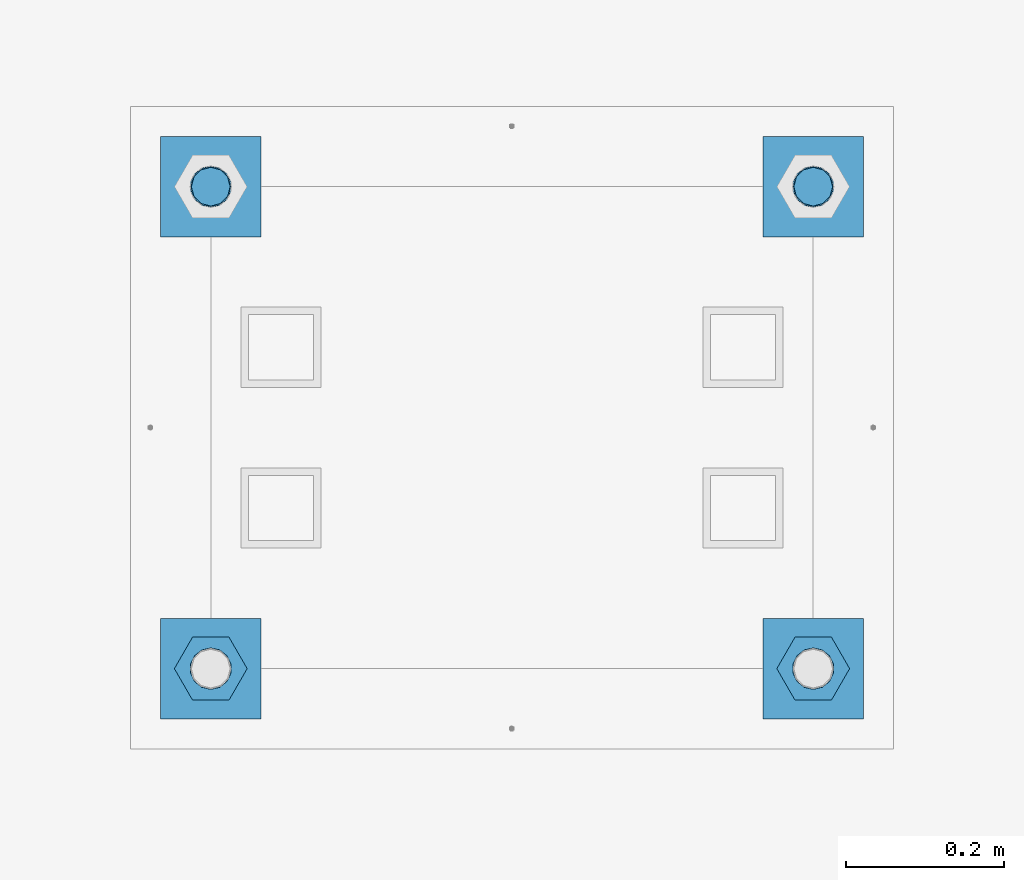
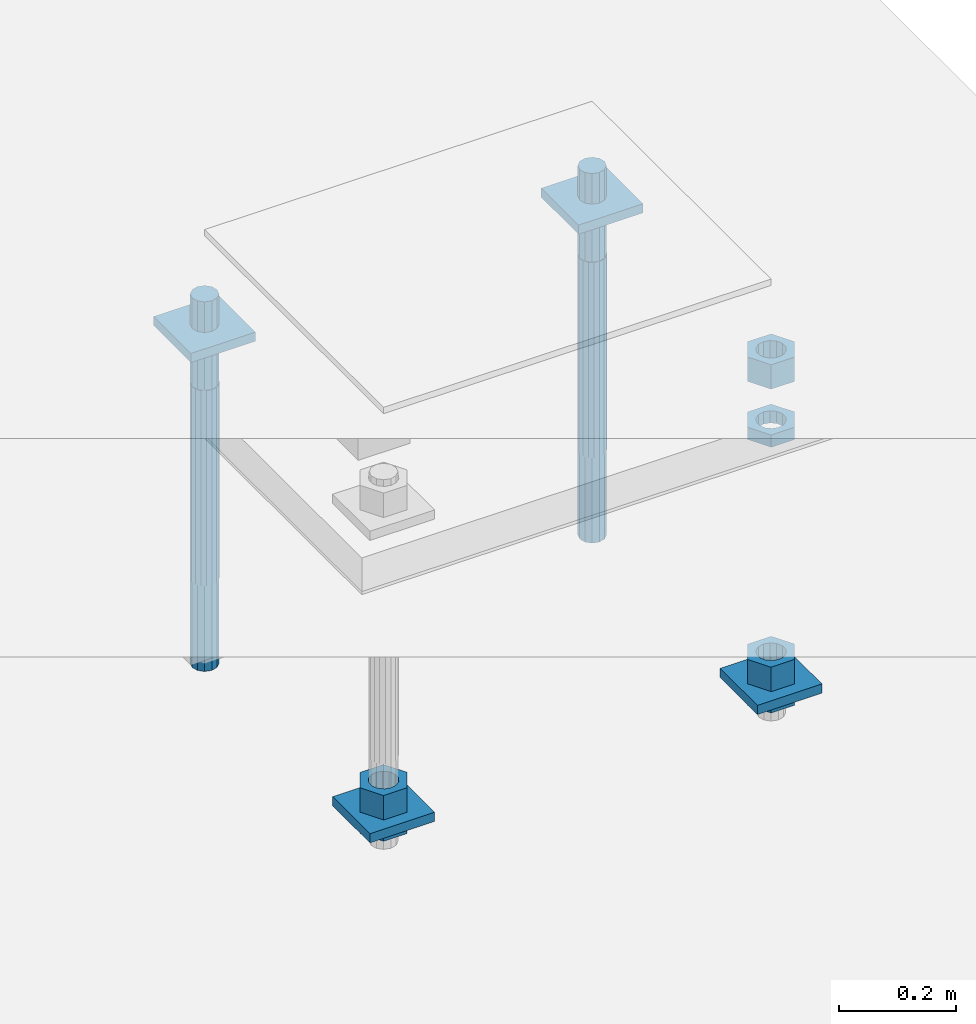
# One storey, part 2632 of 3843: 12 beams, 1 element without a shape of its own.
"""IFC2X3 building model written with IfcOpenShell, lengths in millimetres."""

import ifcopenshell
import ifcopenshell.guid

model = None  # the IFC model being written
_history = None  # IfcOwnerHistory: only IFC2X3 demands one
_inside = {}  # id of a spatial element -> (the spatial element, [elements in it])
_under = {}  # id of a project, library or spatial element -> (it, [spatial elements below it])
_declared = {}  # id of a project -> (the project, [libraries it declares])
_typed = {}  # id of a type object -> (the type object, [elements of that type])
_made_of = {}  # id of a material, layer set ... -> (it, [elements and type objects made of it])


def new_model(schema):
    """Start an empty IFC model of exactly this schema.

    Asked for "IFC4X3", IfcOpenShell would pick the latest addendum, in which some entities
    have other attributes; the version numbers below select the first issue.
    IFC2X3 requires an IfcOwnerHistory on every rooted entity: one is made here for all.
    """
    global model, _history
    if schema == "IFC4X3":
        model = ifcopenshell.file(schema_version=(4, 3, 0, 0))
    else:
        model = ifcopenshell.file(schema=schema)
    _inside.clear()
    _under.clear()
    _declared.clear()
    _typed.clear()
    _made_of.clear()
    _history = None
    if model.schema == "IFC2X3":
        org = make("IfcOrganization", Name="unknown")
        user = make(
            "IfcPersonAndOrganization",
            ThePerson=make("IfcPerson", FamilyName="unknown"),
            TheOrganization=org,
        )
        app = make(
            "IfcApplication",
            ApplicationDeveloper=org,
            Version="unknown",
            ApplicationFullName="unknown",
            ApplicationIdentifier="unknown",
        )
        _history = make(
            "IfcOwnerHistory",
            OwningUser=user,
            OwningApplication=app,
            ChangeAction="ADDED",
            CreationDate=0,
        )
    return model


def make(cls, **values):
    """One entity of the class cls with the attributes given. An attribute that is None is left unset."""
    return model.create_entity(
        cls, **{name: value for name, value in values.items() if value is not None}
    )


def rooted(cls, **values):
    """An entity with a GlobalId (a new one), such as an element, a storey or a relation."""
    return make(cls, GlobalId=ifcopenshell.guid.new(), OwnerHistory=_history, **values)


def si_unit(unit_type, name, prefix=None):
    """IfcSIUnit, for example si_unit("LENGTHUNIT", "METRE", prefix="MILLI")."""
    return make("IfcSIUnit", UnitType=unit_type, Prefix=prefix, Name=name)


def assignment(units):
    """IfcUnitAssignment: the units of a project."""
    return None if units is None else make("IfcUnitAssignment", Units=units)


def point(xyz):
    """IfcCartesianPoint."""
    return None if xyz is None else make("IfcCartesianPoint", Coordinates=xyz)


def direction(xyz):
    """IfcDirection."""
    return None if xyz is None else make("IfcDirection", DirectionRatios=xyz)


def frame(location, z_axis=None, x_axis=None):
    """IfcAxis2Placement3D, a coordinate frame: its origin and axes. An axis left out is left unset."""
    return make(
        "IfcAxis2Placement3D",
        Location=point(location),
        Axis=direction(z_axis),
        RefDirection=direction(x_axis),
    )


def origin_with_axes():
    """The frame at (0, 0, 0) with the z axis (0, 0, 1) and the x axis (1, 0, 0) written out."""
    return frame((0.0, 0.0, 0.0), z_axis=(0.0, 0.0, 1.0), x_axis=(1.0, 0.0, 0.0))


def place(relative_to, where):
    """IfcLocalPlacement: puts the frame where relative to a parent placement (None: the world)."""
    return make(
        "IfcLocalPlacement", PlacementRelTo=relative_to, RelativePlacement=where
    )


def context(
    kind, dimensions, precision=None, world=None, true_north=None, identifier=None
):
    """IfcGeometricRepresentationContext, for example the 3D "Model" context."""
    return make(
        "IfcGeometricRepresentationContext",
        ContextIdentifier=identifier,
        ContextType=kind,
        CoordinateSpaceDimension=dimensions,
        Precision=precision,
        WorldCoordinateSystem=world,
        TrueNorth=true_north,
    )


def subcontext(parent, identifier, kind, view, scale=None):
    """IfcGeometricRepresentationSubContext, for example "Body" below "Model"."""
    return make(
        "IfcGeometricRepresentationSubContext",
        ContextIdentifier=identifier,
        ContextType=kind,
        ParentContext=parent,
        TargetScale=scale,
        TargetView=view,
    )


def project(units=None, contexts=None):
    """IfcProject with its units and contexts."""
    return rooted(
        "IfcProject",
        Name="project",
        RepresentationContexts=contexts,
        UnitsInContext=assignment(units),
    )


def spatial(cls, under=None, at=None, **own):
    """A site, building, storey or space (cls), placed at a placement, below another one or the project."""
    s = rooted(cls, ObjectPlacement=at, **own)
    if under is not None:
        _under.setdefault(under.id(), (under, []))[1].append(s)
    return s


def faces_of(points, faces, orient=None, outer=None):
    """IfcFace entities. A face is a list of loops; a loop is a list of indices into points, from 0.

    orient and outer hold one flag for each loop. By default every Orientation is true, the
    first loop of a face is its IfcFaceOuterBound and the others are IfcFaceBound.
    """
    made = []
    for i, loops in enumerate(faces):
        bounds = []
        for j, loop in enumerate(loops):
            is_outer = j == 0 if outer is None else outer[i][j]
            bounds.append(
                make(
                    "IfcFaceOuterBound" if is_outer else "IfcFaceBound",
                    Bound=make("IfcPolyLoop", Polygon=[points[k] for k in loop]),
                    Orientation=True if orient is None else orient[i][j],
                )
            )
        made.append(make("IfcFace", Bounds=bounds))
    return made


def faceted_brep(points, faces, orient=None, outer=None, voids=None):
    """IfcFacetedBrep: a solid bounded by flat faces; with voids (closed shells), ...WithVoids."""
    shared = [point(p) for p in points]
    hull = make("IfcClosedShell", CfsFaces=faces_of(shared, faces, orient, outer))
    if voids is None:
        return make("IfcFacetedBrep", Outer=hull)
    return make(
        "IfcFacetedBrepWithVoids",
        Outer=hull,
        Voids=[
            make(cls, CfsFaces=faces_of(shared, fs, o, b)) for cls, fs, o, b in voids
        ],
    )


def shape(context_of_items, identifier, shape_type, items):
    """IfcShapeRepresentation: the items that make up one representation, for example the "Body"."""
    return make(
        "IfcShapeRepresentation",
        ContextOfItems=context_of_items,
        RepresentationIdentifier=identifier,
        RepresentationType=shape_type,
        Items=items,
    )


def material(Name=None, Category=None):
    """IfcMaterial."""
    return make("IfcMaterial", Name=Name, Category=Category)


def made_of(thing, what):
    """Note that an element or type object is made of a material, layer set ...; save() writes the relation."""
    if what is not None:
        _made_of.setdefault(what.id(), (what, []))[1].append(thing)
    return thing


def type_object(cls, material=None, **own):
    """A type object (cls), such as IfcWallType, which elements share."""
    return made_of(rooted(cls, **own), material)


def element(
    cls,
    number,
    at=None,
    inside=None,
    cuts=None,
    type_object=None,
    material=None,
    context=None,
    identifier="Body",
    shape_type=None,
    held_by="IfcProductDefinitionShape",
    body=None,
    shapes=None,
    **own,
):
    """One element of the class cls, such as IfcWall. Its Tag is "e" and its number.

    at: its placement. inside: the storey or other place that contains it. cuts: it is an
    opening in that element (IfcRelVoidsElement). A single representation is given by context,
    identifier, shape_type and body (its items); several are given by shapes. held_by: the class
    of the entity that holds the representations. save() writes the other relations.
    """
    e = rooted(cls, Tag="e%d" % number, ObjectPlacement=at, **own)
    if body is not None:
        shapes = [shape(context, identifier, shape_type, body)]
    if shapes is not None:
        e.Representation = make(held_by, Representations=shapes)
    if inside is not None:
        _inside.setdefault(inside.id(), (inside, []))[1].append(e)
    if cuts is not None:
        rooted(
            "IfcRelVoidsElement", RelatingBuildingElement=cuts, RelatedOpeningElement=e
        )
    if type_object is not None:
        _typed.setdefault(type_object.id(), (type_object, []))[1].append(e)
    return made_of(e, material)


def aggregate(whole, parts):
    """IfcRelAggregates: a whole, such as a stair, and the parts it consists of."""
    return rooted("IfcRelAggregates", RelatingObject=whole, RelatedObjects=parts)


def save(model, path):
    """Write the relations noted so far, then the file.

    IfcRelAggregates (storeys below a building ...), IfcRelContainedInSpatialStructure (elements
    in a storey), IfcRelDefinesByType, IfcRelAssociatesMaterial and IfcRelDeclares: one each for
    every whole, place, type object, material and project.
    """
    for whole, parts in _under.values():
        aggregate(whole, parts)
    for where, things in _inside.values():
        rooted(
            "IfcRelContainedInSpatialStructure",
            RelatedElements=things,
            RelatingStructure=where,
        )
    for kind, things in _typed.values():
        rooted("IfcRelDefinesByType", RelatedObjects=things, RelatingType=kind)
    for what, things in _made_of.values():
        rooted("IfcRelAssociatesMaterial", RelatedObjects=things, RelatingMaterial=what)
    for by, libraries in _declared.values():
        rooted("IfcRelDeclares", RelatingContext=by, RelatedDefinitions=libraries)
    model.write(path)


model = new_model("IFC2X3")

# Units and contexts
model_context = context("Model", 3, precision=1e-05, world=origin_with_axes())
body_context = subcontext(model_context, "Body", "Model", "MODEL_VIEW")
ifc_project = project(units=[si_unit("LENGTHUNIT", "METRE", prefix="MILLI"), si_unit("AREAUNIT", "SQUARE_METRE"), si_unit("VOLUMEUNIT", "CUBIC_METRE"), si_unit("MASSUNIT", "GRAM", prefix="KILO"), si_unit("TIMEUNIT", "SECOND"), si_unit("PLANEANGLEUNIT", "RADIAN"), si_unit("SOLIDANGLEUNIT", "STERADIAN"), si_unit("THERMODYNAMICTEMPERATUREUNIT", "DEGREE_CELSIUS"), si_unit("LUMINOUSINTENSITYUNIT", "LUMEN")], contexts=[model_context])

# Site, building, storey
site_placement = place(None, origin_with_axes())
site = spatial("IfcSite", under=ifc_project, at=site_placement, CompositionType="ELEMENT")
building_placement = place(site_placement, origin_with_axes())
building = spatial("IfcBuilding", under=site, at=building_placement, Name="Undefined", CompositionType="ELEMENT")
storey_placement = place(building_placement, origin_with_axes())
storey = spatial("IfcBuildingStorey", under=building, at=storey_placement, Name="Undefined", CompositionType="ELEMENT", Elevation=0.0)

# Assembly, beams
assembly_placement = place(storey_placement, origin_with_axes())
assembly = element("IfcElementAssembly", 1, at=assembly_placement, inside=storey, Name="TEMPLATE", AssemblyPlace="NOTDEFINED", PredefinedType="RIGID_FRAME")
ifc_material_1 = material(Name="STEEL/A572-50")
beam_type_1 = type_object("IfcBeamType", PredefinedType="NOTDEFINED")
beam_1_placement = place(assembly_placement, frame((118465.6, 1892.30000152587, 29873.575), z_axis=(1.0, 0.0, 0.0), x_axis=(0.0, 1.0, 0.0)))
beam_1 = element("IfcBeam", 2, at=beam_1_placement, type_object=beam_type_1, material=ifc_material_1, Name="WASHER_PLATE", context=body_context, shape_type="Brep", body=[
    faceted_brep([(0.0, 9.52500000000146, -63.5), (0.0, 9.52500000000146, 63.5), (127.0, 9.52500000000146, 63.5), (127.0, 9.52500000000146, -63.5), (0.0, -9.52500000000146, 63.5), (127.0, -9.52500000000146, 63.5), (0.0, -9.52500000000146, -63.5), (127.0, -9.52500000000146, -63.5)], [[[0, 1, 2, 3]], [[1, 4, 5, 2]], [[4, 6, 7, 5]], [[6, 0, 3, 7]], [[5, 7, 3, 2]], [[6, 4, 1, 0]]]),
])
beam_2_placement = place(assembly_placement, frame((119227.6, 1892.30000152587, 29873.575), z_axis=(1.0, 0.0, 0.0), x_axis=(0.0, 1.0, 0.0)))
beam_2 = element("IfcBeam", 3, at=beam_2_placement, type_object=beam_type_1, material=ifc_material_1, Name="WASHER_PLATE", context=body_context, shape_type="Brep", body=[
    faceted_brep([(0.0, 9.52500000000146, -63.5), (0.0, 9.52500000000146, 63.5), (127.0, 9.52500000000146, 63.5), (127.0, 9.52500000000146, -63.5), (0.0, -9.52500000000146, 63.5), (127.0, -9.52500000000146, 63.5), (0.0, -9.52500000000146, -63.5), (127.0, -9.52500000000146, -63.5)], [[[0, 1, 2, 3]], [[1, 4, 5, 2]], [[4, 6, 7, 5]], [[6, 0, 3, 7]], [[5, 7, 3, 2]], [[6, 4, 1, 0]]]),
])
beam_3_placement = place(assembly_placement, frame((118465.6, 1282.70000152587, 29244.925), z_axis=(1.0, 0.0, 0.0), x_axis=(0.0, 1.0, 0.0)))
beam_3 = element("IfcBeam", 4, at=beam_3_placement, type_object=beam_type_1, material=ifc_material_1, Name="WASHER_PLATE", context=body_context, shape_type="Brep", body=[
    faceted_brep([(0.0, 9.52500000000146, -63.5), (0.0, 9.52500000000146, 63.5), (127.0, 9.52500000000146, 63.5), (127.0, 9.52500000000146, -63.5), (0.0, -9.52500000000146, 63.5), (127.0, -9.52500000000146, 63.5), (0.0, -9.52500000000146, -63.5), (127.0, -9.52500000000146, -63.5)], [[[0, 1, 2, 3]], [[1, 4, 5, 2]], [[4, 6, 7, 5]], [[6, 0, 3, 7]], [[5, 7, 3, 2]], [[6, 4, 1, 0]]]),
])
beam_4_placement = place(assembly_placement, frame((119227.6, 1282.70000152587, 29244.925), z_axis=(1.0, 0.0, 0.0), x_axis=(0.0, 1.0, 0.0)))
beam_4 = element("IfcBeam", 5, at=beam_4_placement, type_object=beam_type_1, material=ifc_material_1, Name="WASHER_PLATE", context=body_context, shape_type="Brep", body=[
    faceted_brep([(0.0, 9.52500000000146, -63.5), (0.0, 9.52500000000146, 63.5), (127.0, 9.52500000000146, 63.5), (127.0, 9.52500000000146, -63.5), (0.0, -9.52500000000146, 63.5), (127.0, -9.52500000000146, 63.5), (0.0, -9.52500000000146, -63.5), (127.0, -9.52500000000146, -63.5)], [[[0, 1, 2, 3]], [[1, 4, 5, 2]], [[4, 6, 7, 5]], [[6, 0, 3, 7]], [[5, 7, 3, 2]], [[6, 4, 1, 0]]]),
])
ifc_material_2 = material(Name="STEEL/A36")
beam_type_2 = type_object("IfcBeamType", Name="2_HALF_NUT", PredefinedType="NOTDEFINED")
beam_5_placement = place(assembly_placement, frame((118465.6, 1346.20000152587, 29235.4), z_axis=(0.0, 1.0, 0.0), x_axis=(0.0, 0.0, -1.0)))
beam_5 = element("IfcBeam", 6, at=beam_5_placement, type_object=beam_type_2, material=ifc_material_2, Name="NUT", ObjectType="2_HALF_NUT", context=body_context, shape_type="Brep", body=[
    faceted_brep([(0.0, -46.0369987487793, 0.0), (0.0, -23.0184993743896, -39.869213104248), (25.4000000000015, -23.0184993743896, -39.869213104248), (25.4000000000015, -46.0369987487793, 0.0), (0.0, 23.0184993743896, -39.869213104248), (25.4000000000015, 23.0184993743896, -39.869213104248), (0.0, 46.0369987487793, 0.0), (25.4000000000015, 46.0369987487793, 0.0), (0.0, 23.0184993743896, 39.869213104248), (25.4000000000015, 23.0184993743896, 39.869213104248), (0.0, -23.0184993743896, 39.869213104248), (25.4000000000015, -23.0184993743896, 39.869213104248), (0.0, 0.0, 26.1940002441406), (0.0, 11.3650617044477, 23.5999013092805), (25.4000000000015, 11.3650617044477, 23.5999013092805), (25.4000000000015, 0.0, 26.1940002441406), (0.0, 20.4791109456419, 16.3316083006721), (25.4000000000015, 20.4791109456419, 16.3316083006721), (0.0, 25.5370200498292, 5.82867859874386), (25.4000000000015, 25.5370200498292, 5.82867859874386), (0.0, 25.5370200498292, -5.82867859874386), (25.4000000000015, 25.5370200498292, -5.82867859874386), (0.0, 20.4791109456419, -16.3316083006721), (25.4000000000015, 20.4791109456419, -16.3316083006721), (0.0, 11.3650617044477, -23.5999013092805), (25.4000000000015, 11.3650617044477, -23.5999013092805), (0.0, 0.0, -26.1940002441406), (25.4000000000015, 0.0, -26.1940002441406), (0.0, -11.3650617044477, -23.5999013092805), (25.4000000000015, -11.3650617044477, -23.5999013092805), (0.0, -20.4791109456419, -16.3316083006721), (25.4000000000015, -20.4791109456419, -16.3316083006721), (0.0, -25.5370200498292, -5.82867859874386), (25.4000000000015, -25.5370200498292, -5.82867859874386), (0.0, -25.5370200498292, 5.82867859874386), (25.4000000000015, -25.5370200498292, 5.82867859874386), (0.0, -20.4791109456419, 16.3316083006721), (25.4000000000015, -20.4791109456419, 16.3316083006721), (0.0, -11.3650617044477, 23.5999013092805), (25.4000000000015, -11.3650617044477, 23.5999013092805)], [[[0, 1, 2, 3]], [[1, 4, 5, 2]], [[4, 6, 7, 5]], [[6, 8, 9, 7]], [[8, 10, 11, 9]], [[10, 0, 3, 11]], [[12, 13, 14, 15]], [[13, 16, 17, 14]], [[16, 18, 19, 17]], [[18, 20, 21, 19]], [[20, 22, 23, 21]], [[22, 24, 25, 23]], [[24, 26, 27, 25]], [[26, 28, 29, 27]], [[28, 30, 31, 29]], [[30, 32, 33, 31]], [[32, 34, 35, 33]], [[34, 36, 37, 35]], [[36, 38, 39, 37]], [[38, 12, 15, 39]], [[5, 7, 9, 11, 3, 2], [17, 19, 21, 23, 25, 27, 29, 31, 33, 35, 37, 39, 15, 14]], [[10, 8, 6, 4, 1, 0], [38, 36, 34, 32, 30, 28, 26, 24, 22, 20, 18, 16, 13, 12]]]),
])
beam_6_placement = place(assembly_placement, frame((119227.6, 1346.20000152587, 29787.85), z_axis=(0.0, 1.0, 0.0), x_axis=(0.0, 0.0, -1.0)))
beam_6 = element("IfcBeam", 7, at=beam_6_placement, type_object=beam_type_2, material=ifc_material_2, Name="NUT", ObjectType="2_HALF_NUT", context=body_context, shape_type="Brep", body=[
    faceted_brep([(0.0, -46.0369987487793, 0.0), (0.0, -23.0184993743896, -39.869213104248), (25.4000000000015, -23.0184993743896, -39.869213104248), (25.4000000000015, -46.0369987487793, 0.0), (0.0, 23.0184993743896, -39.869213104248), (25.4000000000015, 23.0184993743896, -39.869213104248), (0.0, 46.0369987487793, 0.0), (25.4000000000015, 46.0369987487793, 0.0), (0.0, 23.0184993743896, 39.869213104248), (25.4000000000015, 23.0184993743896, 39.869213104248), (0.0, -23.0184993743896, 39.869213104248), (25.4000000000015, -23.0184993743896, 39.869213104248), (0.0, 0.0, 26.1940002441406), (0.0, 11.3650617044477, 23.5999013092805), (25.4000000000015, 11.3650617044477, 23.5999013092805), (25.4000000000015, 0.0, 26.1940002441406), (0.0, 20.4791109456419, 16.3316083006721), (25.4000000000015, 20.4791109456419, 16.3316083006721), (0.0, 25.5370200498292, 5.82867859874386), (25.4000000000015, 25.5370200498292, 5.82867859874386), (0.0, 25.5370200498292, -5.82867859874386), (25.4000000000015, 25.5370200498292, -5.82867859874386), (0.0, 20.4791109456419, -16.3316083006721), (25.4000000000015, 20.4791109456419, -16.3316083006721), (0.0, 11.3650617044477, -23.5999013092805), (25.4000000000015, 11.3650617044477, -23.5999013092805), (0.0, 0.0, -26.1940002441406), (25.4000000000015, 0.0, -26.1940002441406), (0.0, -11.3650617044477, -23.5999013092805), (25.4000000000015, -11.3650617044477, -23.5999013092805), (0.0, -20.4791109456419, -16.3316083006721), (25.4000000000015, -20.4791109456419, -16.3316083006721), (0.0, -25.5370200498292, -5.82867859874386), (25.4000000000015, -25.5370200498292, -5.82867859874386), (0.0, -25.5370200498292, 5.82867859874386), (25.4000000000015, -25.5370200498292, 5.82867859874386), (0.0, -20.4791109456419, 16.3316083006721), (25.4000000000015, -20.4791109456419, 16.3316083006721), (0.0, -11.3650617044477, 23.5999013092805), (25.4000000000015, -11.3650617044477, 23.5999013092805)], [[[0, 1, 2, 3]], [[1, 4, 5, 2]], [[4, 6, 7, 5]], [[6, 8, 9, 7]], [[8, 10, 11, 9]], [[10, 0, 3, 11]], [[12, 13, 14, 15]], [[13, 16, 17, 14]], [[16, 18, 19, 17]], [[18, 20, 21, 19]], [[20, 22, 23, 21]], [[22, 24, 25, 23]], [[24, 26, 27, 25]], [[26, 28, 29, 27]], [[28, 30, 31, 29]], [[30, 32, 33, 31]], [[32, 34, 35, 33]], [[34, 36, 37, 35]], [[36, 38, 39, 37]], [[38, 12, 15, 39]], [[5, 7, 9, 11, 3, 2], [17, 19, 21, 23, 25, 27, 29, 31, 33, 35, 37, 39, 15, 14]], [[10, 8, 6, 4, 1, 0], [38, 36, 34, 32, 30, 28, 26, 24, 22, 20, 18, 16, 13, 12]]]),
])
beam_7_placement = place(assembly_placement, frame((119227.6, 1346.20000152587, 29235.4), z_axis=(0.0, 1.0, 0.0), x_axis=(0.0, 0.0, -1.0)))
beam_7 = element("IfcBeam", 8, at=beam_7_placement, type_object=beam_type_2, material=ifc_material_2, Name="NUT", ObjectType="2_HALF_NUT", context=body_context, shape_type="Brep", body=[
    faceted_brep([(0.0, -46.0369987487793, 0.0), (0.0, -23.0184993743896, -39.869213104248), (25.4000000000015, -23.0184993743896, -39.869213104248), (25.4000000000015, -46.0369987487793, 0.0), (0.0, 23.0184993743896, -39.869213104248), (25.4000000000015, 23.0184993743896, -39.869213104248), (0.0, 46.0369987487793, 0.0), (25.4000000000015, 46.0369987487793, 0.0), (0.0, 23.0184993743896, 39.869213104248), (25.4000000000015, 23.0184993743896, 39.869213104248), (0.0, -23.0184993743896, 39.869213104248), (25.4000000000015, -23.0184993743896, 39.869213104248), (0.0, 0.0, 26.1940002441406), (0.0, 11.3650617044477, 23.5999013092805), (25.4000000000015, 11.3650617044477, 23.5999013092805), (25.4000000000015, 0.0, 26.1940002441406), (0.0, 20.4791109456419, 16.3316083006721), (25.4000000000015, 20.4791109456419, 16.3316083006721), (0.0, 25.5370200498292, 5.82867859874386), (25.4000000000015, 25.5370200498292, 5.82867859874386), (0.0, 25.5370200498292, -5.82867859874386), (25.4000000000015, 25.5370200498292, -5.82867859874386), (0.0, 20.4791109456419, -16.3316083006721), (25.4000000000015, 20.4791109456419, -16.3316083006721), (0.0, 11.3650617044477, -23.5999013092805), (25.4000000000015, 11.3650617044477, -23.5999013092805), (0.0, 0.0, -26.1940002441406), (25.4000000000015, 0.0, -26.1940002441406), (0.0, -11.3650617044477, -23.5999013092805), (25.4000000000015, -11.3650617044477, -23.5999013092805), (0.0, -20.4791109456419, -16.3316083006721), (25.4000000000015, -20.4791109456419, -16.3316083006721), (0.0, -25.5370200498292, -5.82867859874386), (25.4000000000015, -25.5370200498292, -5.82867859874386), (0.0, -25.5370200498292, 5.82867859874386), (25.4000000000015, -25.5370200498292, 5.82867859874386), (0.0, -20.4791109456419, 16.3316083006721), (25.4000000000015, -20.4791109456419, 16.3316083006721), (0.0, -11.3650617044477, 23.5999013092805), (25.4000000000015, -11.3650617044477, 23.5999013092805)], [[[0, 1, 2, 3]], [[1, 4, 5, 2]], [[4, 6, 7, 5]], [[6, 8, 9, 7]], [[8, 10, 11, 9]], [[10, 0, 3, 11]], [[12, 13, 14, 15]], [[13, 16, 17, 14]], [[16, 18, 19, 17]], [[18, 20, 21, 19]], [[20, 22, 23, 21]], [[22, 24, 25, 23]], [[24, 26, 27, 25]], [[26, 28, 29, 27]], [[28, 30, 31, 29]], [[30, 32, 33, 31]], [[32, 34, 35, 33]], [[34, 36, 37, 35]], [[36, 38, 39, 37]], [[38, 12, 15, 39]], [[5, 7, 9, 11, 3, 2], [17, 19, 21, 23, 25, 27, 29, 31, 33, 35, 37, 39, 15, 14]], [[10, 8, 6, 4, 1, 0], [38, 36, 34, 32, 30, 28, 26, 24, 22, 20, 18, 16, 13, 12]]]),
])
beam_type_3 = type_object("IfcBeamType", Name="2_HEAVY_HEX_NUT", PredefinedType="NOTDEFINED")
beam_8_placement = place(assembly_placement, frame((118465.6, 1346.20000152587, 29305.25), z_axis=(0.0, 1.0, 0.0), x_axis=(0.0, 0.0, -1.0)))
beam_8 = element("IfcBeam", 9, at=beam_8_placement, type_object=beam_type_3, material=ifc_material_2, Name="NUT", ObjectType="2_HEAVY_HEX_NUT", context=body_context, shape_type="Brep", body=[
    faceted_brep([(0.0, -46.0369987487793, 0.0), (0.0, -23.0184993743896, -39.869213104248), (50.7999999999993, -23.0184993743896, -39.869213104248), (50.7999999999993, -46.0369987487793, 0.0), (0.0, 23.0184993743896, -39.869213104248), (50.7999999999993, 23.0184993743896, -39.869213104248), (0.0, 46.0369987487793, 0.0), (50.7999999999993, 46.0369987487793, 0.0), (0.0, 23.0184993743896, 39.869213104248), (50.7999999999993, 23.0184993743896, 39.869213104248), (0.0, -23.0184993743896, 39.869213104248), (50.7999999999993, -23.0184993743896, 39.869213104248), (0.0, 0.0, 26.1940002441406), (0.0, 11.3650617044477, 23.5999013092805), (50.7999999999993, 11.3650617044477, 23.5999013092805), (50.7999999999993, 0.0, 26.1940002441406), (0.0, 20.4791109456419, 16.3316083006721), (50.7999999999993, 20.4791109456419, 16.3316083006721), (0.0, 25.5370200498292, 5.82867859874386), (50.7999999999993, 25.5370200498292, 5.82867859874386), (0.0, 25.5370200498292, -5.82867859874386), (50.7999999999993, 25.5370200498292, -5.82867859874386), (0.0, 20.4791109456419, -16.3316083006721), (50.7999999999993, 20.4791109456419, -16.3316083006721), (0.0, 11.3650617044477, -23.5999013092805), (50.7999999999993, 11.3650617044477, -23.5999013092805), (0.0, 0.0, -26.1940002441406), (50.7999999999993, 0.0, -26.1940002441406), (0.0, -11.3650617044477, -23.5999013092805), (50.7999999999993, -11.3650617044477, -23.5999013092805), (0.0, -20.4791109456419, -16.3316083006721), (50.7999999999993, -20.4791109456419, -16.3316083006721), (0.0, -25.5370200498292, -5.82867859874386), (50.7999999999993, -25.5370200498292, -5.82867859874386), (0.0, -25.5370200498292, 5.82867859874386), (50.7999999999993, -25.5370200498292, 5.82867859874386), (0.0, -20.4791109456419, 16.3316083006721), (50.7999999999993, -20.4791109456419, 16.3316083006721), (0.0, -11.3650617044477, 23.5999013092805), (50.7999999999993, -11.3650617044477, 23.5999013092805)], [[[0, 1, 2, 3]], [[1, 4, 5, 2]], [[4, 6, 7, 5]], [[6, 8, 9, 7]], [[8, 10, 11, 9]], [[10, 0, 3, 11]], [[12, 13, 14, 15]], [[13, 16, 17, 14]], [[16, 18, 19, 17]], [[18, 20, 21, 19]], [[20, 22, 23, 21]], [[22, 24, 25, 23]], [[24, 26, 27, 25]], [[26, 28, 29, 27]], [[28, 30, 31, 29]], [[30, 32, 33, 31]], [[32, 34, 35, 33]], [[34, 36, 37, 35]], [[36, 38, 39, 37]], [[38, 12, 15, 39]], [[5, 7, 9, 11, 3, 2], [17, 19, 21, 23, 25, 27, 29, 31, 33, 35, 37, 39, 15, 14]], [[10, 8, 6, 4, 1, 0], [38, 36, 34, 32, 30, 28, 26, 24, 22, 20, 18, 16, 13, 12]]]),
])
beam_9_placement = place(assembly_placement, frame((119227.6, 1346.20000152587, 29933.9), z_axis=(0.0, 1.0, 0.0), x_axis=(0.0, 0.0, -1.0)))
beam_9 = element("IfcBeam", 10, at=beam_9_placement, type_object=beam_type_3, material=ifc_material_2, Name="NUT", ObjectType="2_HEAVY_HEX_NUT", context=body_context, shape_type="Brep", body=[
    faceted_brep([(0.0, -46.0369987487793, 0.0), (0.0, -23.0184993743896, -39.869213104248), (50.7999999999993, -23.0184993743896, -39.869213104248), (50.7999999999993, -46.0369987487793, 0.0), (0.0, 23.0184993743896, -39.869213104248), (50.7999999999993, 23.0184993743896, -39.869213104248), (0.0, 46.0369987487793, 0.0), (50.7999999999993, 46.0369987487793, 0.0), (0.0, 23.0184993743896, 39.869213104248), (50.7999999999993, 23.0184993743896, 39.869213104248), (0.0, -23.0184993743896, 39.869213104248), (50.7999999999993, -23.0184993743896, 39.869213104248), (0.0, 0.0, 26.1940002441406), (0.0, 11.3650617044477, 23.5999013092805), (50.7999999999993, 11.3650617044477, 23.5999013092805), (50.7999999999993, 0.0, 26.1940002441406), (0.0, 20.4791109456419, 16.3316083006721), (50.7999999999993, 20.4791109456419, 16.3316083006721), (0.0, 25.5370200498292, 5.82867859874386), (50.7999999999993, 25.5370200498292, 5.82867859874386), (0.0, 25.5370200498292, -5.82867859874386), (50.7999999999993, 25.5370200498292, -5.82867859874386), (0.0, 20.4791109456419, -16.3316083006721), (50.7999999999993, 20.4791109456419, -16.3316083006721), (0.0, 11.3650617044477, -23.5999013092805), (50.7999999999993, 11.3650617044477, -23.5999013092805), (0.0, 0.0, -26.1940002441406), (50.7999999999993, 0.0, -26.1940002441406), (0.0, -11.3650617044477, -23.5999013092805), (50.7999999999993, -11.3650617044477, -23.5999013092805), (0.0, -20.4791109456419, -16.3316083006721), (50.7999999999993, -20.4791109456419, -16.3316083006721), (0.0, -25.5370200498292, -5.82867859874386), (50.7999999999993, -25.5370200498292, -5.82867859874386), (0.0, -25.5370200498292, 5.82867859874386), (50.7999999999993, -25.5370200498292, 5.82867859874386), (0.0, -20.4791109456419, 16.3316083006721), (50.7999999999993, -20.4791109456419, 16.3316083006721), (0.0, -11.3650617044477, 23.5999013092805), (50.7999999999993, -11.3650617044477, 23.5999013092805)], [[[0, 1, 2, 3]], [[1, 4, 5, 2]], [[4, 6, 7, 5]], [[6, 8, 9, 7]], [[8, 10, 11, 9]], [[10, 0, 3, 11]], [[12, 13, 14, 15]], [[13, 16, 17, 14]], [[16, 18, 19, 17]], [[18, 20, 21, 19]], [[20, 22, 23, 21]], [[22, 24, 25, 23]], [[24, 26, 27, 25]], [[26, 28, 29, 27]], [[28, 30, 31, 29]], [[30, 32, 33, 31]], [[32, 34, 35, 33]], [[34, 36, 37, 35]], [[36, 38, 39, 37]], [[38, 12, 15, 39]], [[5, 7, 9, 11, 3, 2], [17, 19, 21, 23, 25, 27, 29, 31, 33, 35, 37, 39, 15, 14]], [[10, 8, 6, 4, 1, 0], [38, 36, 34, 32, 30, 28, 26, 24, 22, 20, 18, 16, 13, 12]]]),
])
beam_10_placement = place(assembly_placement, frame((119227.6, 1346.20000152587, 29305.25), z_axis=(0.0, 1.0, 0.0), x_axis=(0.0, 0.0, -1.0)))
beam_10 = element("IfcBeam", 11, at=beam_10_placement, type_object=beam_type_3, material=ifc_material_2, Name="NUT", ObjectType="2_HEAVY_HEX_NUT", context=body_context, shape_type="Brep", body=[
    faceted_brep([(0.0, -46.0369987487793, 0.0), (0.0, -23.0184993743896, -39.869213104248), (50.7999999999993, -23.0184993743896, -39.869213104248), (50.7999999999993, -46.0369987487793, 0.0), (0.0, 23.0184993743896, -39.869213104248), (50.7999999999993, 23.0184993743896, -39.869213104248), (0.0, 46.0369987487793, 0.0), (50.7999999999993, 46.0369987487793, 0.0), (0.0, 23.0184993743896, 39.869213104248), (50.7999999999993, 23.0184993743896, 39.869213104248), (0.0, -23.0184993743896, 39.869213104248), (50.7999999999993, -23.0184993743896, 39.869213104248), (0.0, 0.0, 26.1940002441406), (0.0, 11.3650617044477, 23.5999013092805), (50.7999999999993, 11.3650617044477, 23.5999013092805), (50.7999999999993, 0.0, 26.1940002441406), (0.0, 20.4791109456419, 16.3316083006721), (50.7999999999993, 20.4791109456419, 16.3316083006721), (0.0, 25.5370200498292, 5.82867859874386), (50.7999999999993, 25.5370200498292, 5.82867859874386), (0.0, 25.5370200498292, -5.82867859874386), (50.7999999999993, 25.5370200498292, -5.82867859874386), (0.0, 20.4791109456419, -16.3316083006721), (50.7999999999993, 20.4791109456419, -16.3316083006721), (0.0, 11.3650617044477, -23.5999013092805), (50.7999999999993, 11.3650617044477, -23.5999013092805), (0.0, 0.0, -26.1940002441406), (50.7999999999993, 0.0, -26.1940002441406), (0.0, -11.3650617044477, -23.5999013092805), (50.7999999999993, -11.3650617044477, -23.5999013092805), (0.0, -20.4791109456419, -16.3316083006721), (50.7999999999993, -20.4791109456419, -16.3316083006721), (0.0, -25.5370200498292, -5.82867859874386), (50.7999999999993, -25.5370200498292, -5.82867859874386), (0.0, -25.5370200498292, 5.82867859874386), (50.7999999999993, -25.5370200498292, 5.82867859874386), (0.0, -20.4791109456419, 16.3316083006721), (50.7999999999993, -20.4791109456419, 16.3316083006721), (0.0, -11.3650617044477, 23.5999013092805), (50.7999999999993, -11.3650617044477, 23.5999013092805)], [[[0, 1, 2, 3]], [[1, 4, 5, 2]], [[4, 6, 7, 5]], [[6, 8, 9, 7]], [[8, 10, 11, 9]], [[10, 0, 3, 11]], [[12, 13, 14, 15]], [[13, 16, 17, 14]], [[16, 18, 19, 17]], [[18, 20, 21, 19]], [[20, 22, 23, 21]], [[22, 24, 25, 23]], [[24, 26, 27, 25]], [[26, 28, 29, 27]], [[28, 30, 31, 29]], [[30, 32, 33, 31]], [[32, 34, 35, 33]], [[34, 36, 37, 35]], [[36, 38, 39, 37]], [[38, 12, 15, 39]], [[5, 7, 9, 11, 3, 2], [17, 19, 21, 23, 25, 27, 29, 31, 33, 35, 37, 39, 15, 14]], [[10, 8, 6, 4, 1, 0], [38, 36, 34, 32, 30, 28, 26, 24, 22, 20, 18, 16, 13, 12]]]),
])
ifc_material_3 = material()
beam_type_4 = type_object("IfcBeamType", PredefinedType="NOTDEFINED")
beam_11_placement = place(assembly_placement, frame((118465.600001526, 1955.79999999999, 29762.45), z_axis=(1.0, 0.0, 0.0), x_axis=(0.0, 0.0, -1.0)))
beam_11 = element("IfcBeam", 12, at=beam_11_placement, type_object=beam_type_4, material=ifc_material_3, Name="ANCHOR_ROD", context=body_context, shape_type="Brep", body=[
    faceted_brep([(0.0, -23.4665401257807, -9.72015918207035), (0.0, -17.9605122421344, -17.9605122421417), (406.399999999998, -17.9605122421344, -17.9605122421417), (406.399999999998, -23.4665401257807, -9.72015918207035), (0.0, -9.72015918207762, -23.466540125788), (406.399999999998, -9.72015918207762, -23.466540125788), (0.0, 0.0, -25.4000000000015), (406.399999999998, 0.0, -25.4000000000015), (0.0, 9.72015918207762, -23.466540125788), (406.399999999998, 9.72015918207762, -23.466540125788), (0.0, 17.9605122421344, -17.9605122421417), (406.399999999998, 17.9605122421344, -17.9605122421417), (0.0, 23.4665401257807, -9.72015918207035), (406.399999999998, 23.4665401257807, -9.72015918207035), (0.0, 25.3999996185303, 0.0), (406.399999999998, 25.3999999999942, 0.0), (0.0, 23.4665401257807, 9.72015918207035), (406.399999999998, 23.4665401257807, 9.72015918207035), (0.0, 17.9605122421344, 17.9605122421417), (406.399999999998, 17.9605122421344, 17.9605122421417), (0.0, 9.72015918207762, 23.466540125788), (406.399999999998, 9.72015918207762, 23.466540125788), (0.0, 0.0, 25.4000000000015), (406.399999999998, 0.0, 25.4000000000015), (0.0, -9.72015918207762, 23.466540125788), (406.399999999998, -9.72015918207762, 23.466540125788), (0.0, -17.9605122421344, 17.9605122421417), (406.399999999998, -17.9605122421344, 17.9605122421417), (0.0, -23.4665401257807, 9.72015918207035), (406.399999999998, -23.4665401257807, 9.72015918207035), (0.0, -25.3999996185303, 0.0), (406.399999999998, -25.3999999999942, 0.0), (584.200000000001, -12.2499999999854, -21.2176223927163), (584.200000000001, 1.45519152283669e-11, -24.5), (584.200000000001, 12.2500000000146, -21.2176223927163), (584.200000000001, 21.2176223927381, -12.25), (584.200000000001, 24.5000000000146, 0.0), (584.200000000001, 21.2176223927381, 12.25), (584.200000000001, 12.2500000000146, 21.2176223927163), (584.200000000001, 1.45519152283669e-11, 24.5), (584.200000000001, -12.2499999999854, 21.2176223927163), (584.200000000001, -21.217622392709, 12.25), (584.200000000001, -24.4999999999854, 0.0), (584.200000000001, -21.217622392709, -12.25), (406.399999999998, -24.4999999999854, 0.0), (406.399999999998, -21.217622392709, -12.25), (406.399999999998, -12.2499999999854, -21.2176223927163), (406.399999999998, 1.45519152283669e-11, -24.5), (406.399999999998, 12.2500000000146, -21.2176223927163), (406.399999999998, 21.2176223927381, -12.25), (406.399999999998, 24.5000000000146, 0.0), (406.399999999998, 21.2176223927381, 12.25), (406.399999999998, 12.2500000000146, 21.2176223927163), (406.399999999998, 1.45519152283669e-11, 24.5), (406.399999999998, -12.2499999999854, 21.2176223927163), (406.399999999998, -21.217622392709, 12.25), (0.0, 12.2500000000146, 21.2176223927163), (0.0, 1.45519152283669e-11, 24.5), (0.0, -12.2499999999854, 21.2176223927163), (0.0, -21.217622392709, 12.25), (0.0, -24.4999999999854, 0.0), (0.0, -21.217622392709, -12.25), (0.0, -12.2499999999854, -21.2176223927163), (0.0, 1.45519152283669e-11, -24.5), (0.0, 12.2500000000146, -21.2176223927163), (0.0, 21.2176223927381, -12.25), (0.0, 24.5000000000146, 0.0), (0.0, 21.2176223927381, 12.25), (-184.150000000001, -21.217622392709, 12.25), (-184.150000000001, -12.2499999999854, 21.2176223927163), (-184.150000000001, 1.45519152283669e-11, 24.5), (-184.150000000001, 12.2500000000146, 21.2176223927163), (-184.150000000001, 21.2176223927381, 12.25), (-184.150000000001, 24.5000000000146, 0.0), (-184.150000000001, 21.2176223927381, -12.25), (-184.150000000001, 12.2500000000146, -21.2176223927163), (-184.150000000001, 1.45519152283669e-11, -24.5), (-184.150000000001, -12.2499999999854, -21.2176223927163), (-184.150000000001, -21.217622392709, -12.25), (-184.150000000001, -24.4999999999854, 0.0)], [[[0, 1, 2, 3]], [[1, 4, 5, 2]], [[4, 6, 7, 5]], [[6, 8, 9, 7]], [[8, 10, 11, 9]], [[10, 12, 13, 11]], [[12, 14, 15, 13]], [[14, 16, 17, 15]], [[16, 18, 19, 17]], [[18, 20, 21, 19]], [[20, 22, 23, 21]], [[22, 24, 25, 23]], [[24, 26, 27, 25]], [[26, 28, 29, 27]], [[28, 30, 31, 29]], [[32, 33, 34, 35, 36, 37, 38, 39, 40, 41, 42, 43]], [[43, 42, 44, 45]], [[32, 43, 45, 46]], [[33, 32, 46, 47]], [[34, 33, 47, 48]], [[35, 34, 48, 49]], [[36, 35, 49, 50]], [[37, 36, 50, 51]], [[38, 37, 51, 52]], [[39, 38, 52, 53]], [[40, 39, 53, 54]], [[41, 40, 54, 55]], [[42, 41, 55, 44]], [[2, 5, 7, 9, 11, 13, 15, 17, 19, 21, 23, 25, 27, 29, 31, 3], [54, 53, 52, 51, 50, 49, 48, 47, 46, 45, 44, 55]], [[30, 0, 3, 31]], [[28, 26, 24, 22, 20, 18, 16, 14, 12, 10, 8, 6, 4, 1, 0, 30], [56, 57, 58, 59, 60, 61, 62, 63, 64, 65, 66, 67]], [[68, 69, 70, 71, 72, 73, 74, 75, 76, 77, 78, 79]], [[71, 70, 57, 56]], [[72, 71, 56, 67]], [[73, 72, 67, 66]], [[74, 73, 66, 65]], [[75, 74, 65, 64]], [[76, 75, 64, 63]], [[77, 76, 63, 62]], [[78, 77, 62, 61]], [[79, 78, 61, 60]], [[68, 79, 60, 59]], [[69, 68, 59, 58]], [[70, 69, 58, 57]]]),
])
beam_12_placement = place(assembly_placement, frame((119227.600001526, 1955.79999999999, 29762.45), z_axis=(1.0, 0.0, 0.0), x_axis=(0.0, 0.0, -1.0)))
beam_12 = element("IfcBeam", 13, at=beam_12_placement, type_object=beam_type_4, material=ifc_material_3, Name="ANCHOR_ROD", context=body_context, shape_type="Brep", body=[
    faceted_brep([(0.0, -23.4665401257807, -9.72015918207035), (0.0, -17.9605122421344, -17.9605122421417), (406.399999999998, -17.9605122421344, -17.9605122421417), (406.399999999998, -23.4665401257807, -9.72015918207035), (0.0, -9.72015918207762, -23.466540125788), (406.399999999998, -9.72015918207762, -23.466540125788), (0.0, 0.0, -25.4000000000015), (406.399999999998, 0.0, -25.4000000000015), (0.0, 9.72015918207762, -23.466540125788), (406.399999999998, 9.72015918207762, -23.466540125788), (0.0, 17.9605122421344, -17.9605122421417), (406.399999999998, 17.9605122421344, -17.9605122421417), (0.0, 23.4665401257807, -9.72015918207035), (406.399999999998, 23.4665401257807, -9.72015918207035), (0.0, 25.3999996185303, 0.0), (406.399999999998, 25.3999999999942, 0.0), (0.0, 23.4665401257807, 9.72015918207035), (406.399999999998, 23.4665401257807, 9.72015918207035), (0.0, 17.9605122421344, 17.9605122421417), (406.399999999998, 17.9605122421344, 17.9605122421417), (0.0, 9.72015918207762, 23.466540125788), (406.399999999998, 9.72015918207762, 23.466540125788), (0.0, 0.0, 25.4000000000015), (406.399999999998, 0.0, 25.4000000000015), (0.0, -9.72015918207762, 23.466540125788), (406.399999999998, -9.72015918207762, 23.466540125788), (0.0, -17.9605122421344, 17.9605122421417), (406.399999999998, -17.9605122421344, 17.9605122421417), (0.0, -23.4665401257807, 9.72015918207035), (406.399999999998, -23.4665401257807, 9.72015918207035), (0.0, -25.3999996185303, 0.0), (406.399999999998, -25.3999999999942, 0.0), (584.200000000001, -12.2499999999854, -21.2176223927163), (584.200000000001, 1.45519152283669e-11, -24.5), (584.200000000001, 12.2500000000146, -21.2176223927163), (584.200000000001, 21.2176223927381, -12.25), (584.200000000001, 24.5000000000146, 0.0), (584.200000000001, 21.2176223927381, 12.25), (584.200000000001, 12.2500000000146, 21.2176223927163), (584.200000000001, 1.45519152283669e-11, 24.5), (584.200000000001, -12.2499999999854, 21.2176223927163), (584.200000000001, -21.217622392709, 12.25), (584.200000000001, -24.4999999999854, 0.0), (584.200000000001, -21.217622392709, -12.25), (406.399999999998, -24.4999999999854, 0.0), (406.399999999998, -21.217622392709, -12.25), (406.399999999998, -12.2499999999854, -21.2176223927163), (406.399999999998, 1.45519152283669e-11, -24.5), (406.399999999998, 12.2500000000146, -21.2176223927163), (406.399999999998, 21.2176223927381, -12.25), (406.399999999998, 24.5000000000146, 0.0), (406.399999999998, 21.2176223927381, 12.25), (406.399999999998, 12.2500000000146, 21.2176223927163), (406.399999999998, 1.45519152283669e-11, 24.5), (406.399999999998, -12.2499999999854, 21.2176223927163), (406.399999999998, -21.217622392709, 12.25), (0.0, 12.2500000000146, 21.2176223927163), (0.0, 1.45519152283669e-11, 24.5), (0.0, -12.2499999999854, 21.2176223927163), (0.0, -21.217622392709, 12.25), (0.0, -24.4999999999854, 0.0), (0.0, -21.217622392709, -12.25), (0.0, -12.2499999999854, -21.2176223927163), (0.0, 1.45519152283669e-11, -24.5), (0.0, 12.2500000000146, -21.2176223927163), (0.0, 21.2176223927381, -12.25), (0.0, 24.5000000000146, 0.0), (0.0, 21.2176223927381, 12.25), (-184.150000000001, -21.217622392709, 12.25), (-184.150000000001, -12.2499999999854, 21.2176223927163), (-184.150000000001, 1.45519152283669e-11, 24.5), (-184.150000000001, 12.2500000000146, 21.2176223927163), (-184.150000000001, 21.2176223927381, 12.25), (-184.150000000001, 24.5000000000146, 0.0), (-184.150000000001, 21.2176223927381, -12.25), (-184.150000000001, 12.2500000000146, -21.2176223927163), (-184.150000000001, 1.45519152283669e-11, -24.5), (-184.150000000001, -12.2499999999854, -21.2176223927163), (-184.150000000001, -21.217622392709, -12.25), (-184.150000000001, -24.4999999999854, 0.0)], [[[0, 1, 2, 3]], [[1, 4, 5, 2]], [[4, 6, 7, 5]], [[6, 8, 9, 7]], [[8, 10, 11, 9]], [[10, 12, 13, 11]], [[12, 14, 15, 13]], [[14, 16, 17, 15]], [[16, 18, 19, 17]], [[18, 20, 21, 19]], [[20, 22, 23, 21]], [[22, 24, 25, 23]], [[24, 26, 27, 25]], [[26, 28, 29, 27]], [[28, 30, 31, 29]], [[32, 33, 34, 35, 36, 37, 38, 39, 40, 41, 42, 43]], [[43, 42, 44, 45]], [[32, 43, 45, 46]], [[33, 32, 46, 47]], [[34, 33, 47, 48]], [[35, 34, 48, 49]], [[36, 35, 49, 50]], [[37, 36, 50, 51]], [[38, 37, 51, 52]], [[39, 38, 52, 53]], [[40, 39, 53, 54]], [[41, 40, 54, 55]], [[42, 41, 55, 44]], [[2, 5, 7, 9, 11, 13, 15, 17, 19, 21, 23, 25, 27, 29, 31, 3], [54, 53, 52, 51, 50, 49, 48, 47, 46, 45, 44, 55]], [[30, 0, 3, 31]], [[28, 26, 24, 22, 20, 18, 16, 14, 12, 10, 8, 6, 4, 1, 0, 30], [56, 57, 58, 59, 60, 61, 62, 63, 64, 65, 66, 67]], [[68, 69, 70, 71, 72, 73, 74, 75, 76, 77, 78, 79]], [[71, 70, 57, 56]], [[72, 71, 56, 67]], [[73, 72, 67, 66]], [[74, 73, 66, 65]], [[75, 74, 65, 64]], [[76, 75, 64, 63]], [[77, 76, 63, 62]], [[78, 77, 62, 61]], [[79, 78, 61, 60]], [[68, 79, 60, 59]], [[69, 68, 59, 58]], [[70, 69, 58, 57]]]),
])
aggregate(assembly, [beam_11, beam_12, beam_1, beam_2, beam_8, beam_5, beam_3, beam_6, beam_9, beam_10, beam_7, beam_4])

save(model, "model.ifc")
